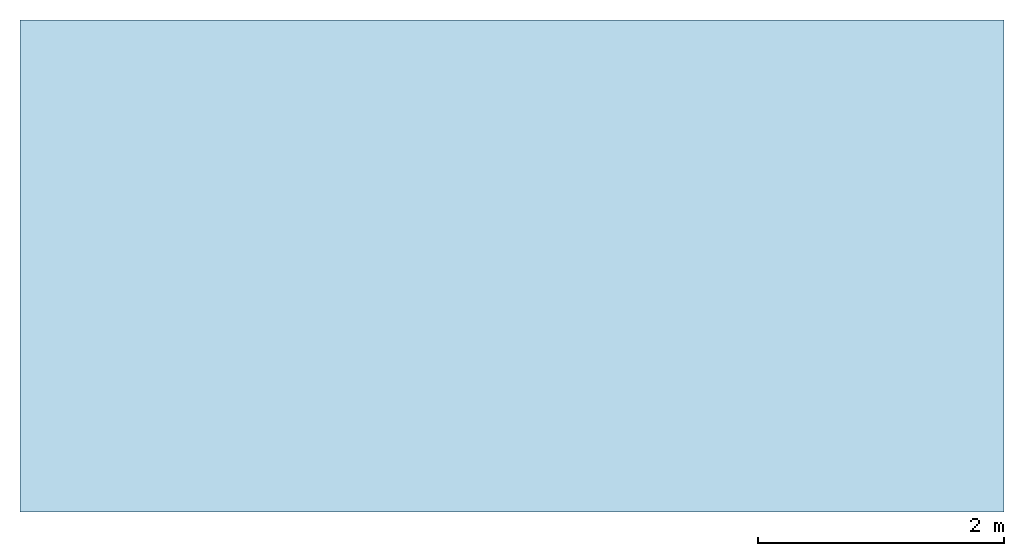
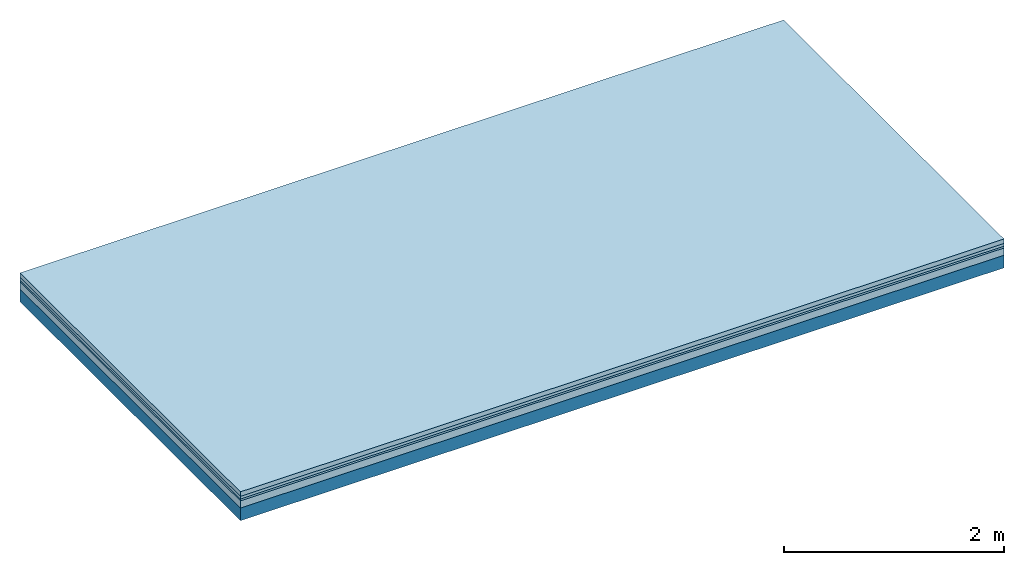
# One storey: 4 plates, 1 member, 1 element without a shape of its own.
"""IFC4 building model written with IfcOpenShell, lengths in metres."""

from ifc_helpers import new_model, si_unit, derived_unit, direction, frame, frame_2d, origin, origin_with_axes, place, context, project, spatial, rectangle, extrude, material, layer, layer_set, type_object, element, aggregate, save


model = new_model("IFC4")

# Units and contexts
plan_context = context("Plan", 3, precision=1e-05, world=origin(), true_north=direction((0.0, 1.0)))
model_context = context("Model", 3, precision=1e-05, world=origin(), true_north=direction((0.0, 1.0)))
ifc_project = project(units=[si_unit("LENGTHUNIT", "METRE"), derived_unit("SOUNDPRESSUREUNIT", [(si_unit("PRESSUREUNIT", "PASCAL", prefix="MICRO"), 0)]), si_unit("ENERGYUNIT", "JOULE", prefix="MEGA"), si_unit("MASSUNIT", "GRAM", prefix="KILO"), derived_unit("THERMALTRANSMITTANCEUNIT", [(si_unit("POWERUNIT", "WATT"), 1), (si_unit("AREAUNIT", "SQUARE_METRE"), -1), (si_unit("THERMODYNAMICTEMPERATUREUNIT", "KELVIN"), -1)]), derived_unit("AREADENSITYUNIT", [(si_unit("MASSUNIT", "GRAM", prefix="KILO"), 1), (si_unit("AREAUNIT", "SQUARE_METRE"), -1)]), derived_unit("USERDEFINED", [(si_unit("ENERGYUNIT", "JOULE", prefix="MEGA"), 1), (si_unit("AREAUNIT", "SQUARE_METRE"), -1)])], contexts=[plan_context, model_context])

# Site, building, storey
site = spatial("IfcSite", under=ifc_project)
building_placement = place(None, origin())
building = spatial("IfcBuilding", under=site, at=building_placement)
storey_placement = place(building_placement, origin())
storey = spatial("IfcBuildingStorey", under=building, at=storey_placement)

# Slab, member, plates
ifc_material_1 = material(Name="Cement screed", Category="04.006")
ifc_layer_1 = layer(ifc_material_1, 0.05, Name="Flooring")
ifc_material_2 = material(Name="Phone Star TRI", Category="03.013")
ifc_layer_2 = layer(ifc_material_2, 0.03, Name="On-material")
ifc_material_3 = material(Name="EP3")
ifc_layer_3 = layer(ifc_material_3, 0.02, Name="Impact sound insulation")
ifc_material_4 = material(Category="03.011")
ifc_layer_4 = layer(ifc_material_4, 0.08, Name="on Supporting structure")
ifc_material_5 = material(Name="no composite action")
ifc_layer_5 = layer(ifc_material_5, 0.0, Name="Bond")
ifc_layer_6 = layer(None, 0.14, Name="Supporting structure")
ifc_layer_set = layer_set([ifc_layer_1, ifc_layer_2, ifc_layer_3, ifc_layer_4, ifc_layer_5, ifc_layer_6])
slab_type = type_object("IfcSlabType", Name="A2478", PredefinedType="NOTDEFINED", material=ifc_layer_set)
slab_placement = place(None, frame((0.0, 0.0, 0.0), z_axis=(0.0, 0.0, -1.0), x_axis=(1.0, 0.0, 0.0)))
slab = element("IfcSlab", 1, at=slab_placement, inside=storey, type_object=slab_type, material=ifc_layer_set, Name="Slab #1")
ifc_material_6 = material()
member_placement = place(slab_placement, origin())
member = element("IfcMember", 2, at=member_placement, material=ifc_material_6, Name="Supporting structure", context=plan_context, shape_type="SweptSolid", body=[
    extrude(rectangle(XDim=1.0, YDim=0.14, at=frame_2d((0.5, 0.07), x_axis=(1.0, 0.0))), frame((0.0, 4.0, 0.18), z_axis=(0.0, -1.0, 0.0), x_axis=(1.0, 0.0, 0.0)), (0.0, 0.0, 1.0), 4.0),
    extrude(rectangle(XDim=1.0, YDim=0.14, at=frame_2d((0.5, 0.07), x_axis=(1.0, 0.0))), frame((1.0, 4.0, 0.18), z_axis=(0.0, -1.0, 0.0), x_axis=(1.0, 0.0, 0.0)), (0.0, 0.0, 1.0), 4.0),
    extrude(rectangle(XDim=1.0, YDim=0.14, at=frame_2d((0.5, 0.07), x_axis=(1.0, 0.0))), frame((2.0, 4.0, 0.18), z_axis=(0.0, -1.0, 0.0), x_axis=(1.0, 0.0, 0.0)), (0.0, 0.0, 1.0), 4.0),
    extrude(rectangle(XDim=1.0, YDim=0.14, at=frame_2d((0.5, 0.07), x_axis=(1.0, 0.0))), frame((3.0, 4.0, 0.18), z_axis=(0.0, -1.0, 0.0), x_axis=(1.0, 0.0, 0.0)), (0.0, 0.0, 1.0), 4.0),
    extrude(rectangle(XDim=1.0, YDim=0.14, at=frame_2d((0.5, 0.07), x_axis=(1.0, 0.0))), frame((4.0, 4.0, 0.18), z_axis=(0.0, -1.0, 0.0), x_axis=(1.0, 0.0, 0.0)), (0.0, 0.0, 1.0), 4.0),
    extrude(rectangle(XDim=1.0, YDim=0.14, at=frame_2d((0.5, 0.07), x_axis=(1.0, 0.0))), frame((5.0, 4.0, 0.18), z_axis=(0.0, -1.0, 0.0), x_axis=(1.0, 0.0, 0.0)), (0.0, 0.0, 1.0), 4.0),
    extrude(rectangle(XDim=1.0, YDim=0.14, at=frame_2d((0.5, 0.07), x_axis=(1.0, 0.0))), frame((6.0, 4.0, 0.18), z_axis=(0.0, -1.0, 0.0), x_axis=(1.0, 0.0, 0.0)), (0.0, 0.0, 1.0), 4.0),
    extrude(rectangle(XDim=1.0, YDim=0.14, at=frame_2d((0.5, 0.07), x_axis=(1.0, 0.0))), frame((7.0, 4.0, 0.18), z_axis=(0.0, -1.0, 0.0), x_axis=(1.0, 0.0, 0.0)), (0.0, 0.0, 1.0), 4.0),
])
plate_1_placement = place(slab_placement, origin())
plate_1 = element("IfcPlate", 3, at=plate_1_placement, material=ifc_material_1, Name="Flooring", context=plan_context, shape_type="SweptSolid", body=[
    extrude(rectangle(XDim=8.0, YDim=4.0, at=frame_2d((4.0, 2.0), x_axis=(1.0, 0.0))), origin_with_axes(), (0.0, 0.0, 1.0), 0.05),
])
plate_2_placement = place(slab_placement, origin())
plate_2 = element("IfcPlate", 4, at=plate_2_placement, material=ifc_material_2, Name="On-material", context=plan_context, shape_type="SweptSolid", body=[
    extrude(rectangle(XDim=8.0, YDim=4.0, at=frame_2d((4.0, 2.0), x_axis=(1.0, 0.0))), frame((0.0, 0.0, 0.05), z_axis=(0.0, 0.0, 1.0), x_axis=(1.0, 0.0, 0.0)), (0.0, 0.0, 1.0), 0.03),
])
plate_3_placement = place(slab_placement, origin())
plate_3 = element("IfcPlate", 5, at=plate_3_placement, material=ifc_material_3, Name="Impact sound insulation", context=plan_context, shape_type="SweptSolid", body=[
    extrude(rectangle(XDim=8.0, YDim=4.0, at=frame_2d((4.0, 2.0), x_axis=(1.0, 0.0))), frame((0.0, 0.0, 0.08), z_axis=(0.0, 0.0, 1.0), x_axis=(1.0, 0.0, 0.0)), (0.0, 0.0, 1.0), 0.02),
])
plate_4_placement = place(slab_placement, origin())
plate_4 = element("IfcPlate", 6, at=plate_4_placement, material=ifc_material_4, Name="on Supporting structure", context=plan_context, shape_type="SweptSolid", body=[
    extrude(rectangle(XDim=8.0, YDim=4.0, at=frame_2d((4.0, 2.0), x_axis=(1.0, 0.0))), frame((0.0, 0.0, 0.1), z_axis=(0.0, 0.0, 1.0), x_axis=(1.0, 0.0, 0.0)), (0.0, 0.0, 1.0), 0.08),
])
aggregate(slab, [plate_1, plate_2, plate_3, plate_4, member])

save(model, "model.ifc")
